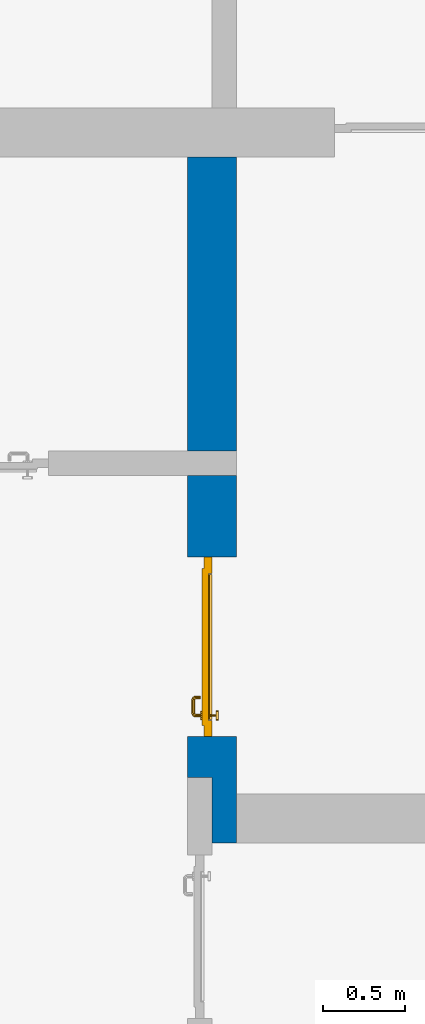
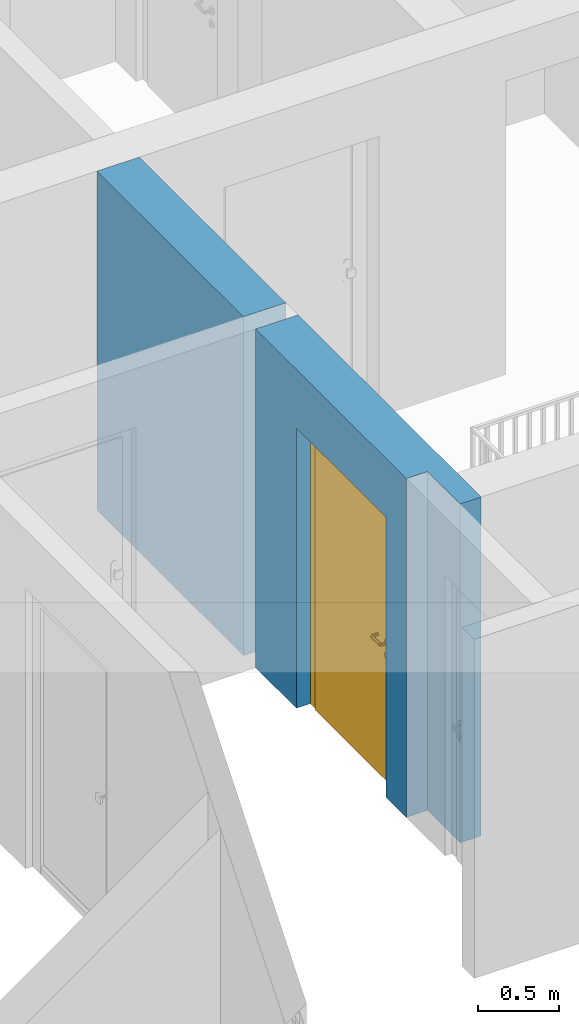
# One storey, part 13 of 54: 1 door, 1 wall, 1 opening.
"""IFC4 building model written with IfcOpenShell, lengths in metres."""

from ifc_helpers import new_model, entity, si_unit, converted_unit, derived_unit, direction, frame, origin_with_axes, place, context, subcontext, project, spatial, polygons, source, transform, mapped, material, type_object, element, fill, save


model = new_model("IFC4")

# Units and contexts
model_context = context("Model", 3, precision=1e-05, world=origin_with_axes(), true_north=direction((0.0, 1.0)))
body_context = subcontext(model_context, "Body", "Model", "MODEL_VIEW")
ifc_project = project(units=[si_unit("LENGTHUNIT", "METRE"), si_unit("AREAUNIT", "SQUARE_METRE"), si_unit("VOLUMEUNIT", "CUBIC_METRE"), converted_unit("PLANEANGLEUNIT", "DEGREE", entity("IfcPlaneAngleMeasure", 0.0174532925199), si_unit("PLANEANGLEUNIT", "RADIAN"), dimensions=[0, 0, 0, 0, 0, 0, 0]), converted_unit("TIMEUNIT", "Year", entity("IfcTimeMeasure", 31556926.0), si_unit("TIMEUNIT", "SECOND"), dimensions=[0, 0, 1, 0, 0, 0, 0]), si_unit("MASSUNIT", "GRAM", prefix="KILO"), si_unit("THERMODYNAMICTEMPERATUREUNIT", "DEGREE_CELSIUS"), si_unit("LUMINOUSINTENSITYUNIT", "LUMEN"), si_unit("ENERGYUNIT", "JOULE", prefix="MEGA"), derived_unit("THERMALCONDUCTANCEUNIT", [(si_unit("POWERUNIT", "WATT"), 1), (si_unit("LENGTHUNIT", "METRE"), -1), (si_unit("THERMODYNAMICTEMPERATUREUNIT", "KELVIN"), -1)]), derived_unit("SPECIFICHEATCAPACITYUNIT", [(si_unit("ENERGYUNIT", "JOULE"), 1), (si_unit("MASSUNIT", "GRAM", prefix="KILO"), -1), (si_unit("THERMODYNAMICTEMPERATUREUNIT", "KELVIN"), -1)]), derived_unit("MASSDENSITYUNIT", [(si_unit("MASSUNIT", "GRAM", prefix="KILO"), 1), (si_unit("VOLUMEUNIT", "CUBIC_METRE"), -1)])], contexts=[model_context])

# Site, building, storey
site_placement = place(None, origin_with_axes())
site = spatial("IfcSite", under=ifc_project, at=site_placement, CompositionType="ELEMENT")
building_placement = place(site_placement, origin_with_axes())
building = spatial("IfcBuilding", under=site, at=building_placement, CompositionType="ELEMENT")
storey_placement = place(building_placement, frame((0.0, 0.0, 9.18), z_axis=(0.0, 0.0, 1.0), x_axis=(1.0, 0.0, 0.0)))
storey = spatial("IfcBuildingStorey", under=building, at=storey_placement, Name="3. Geschoss", CompositionType="ELEMENT", Elevation=9.18)

# Wall, opening, door
ifc_material = material()
wall_type = type_object("IfcWallType", Name="300", PredefinedType="NOTDEFINED")
wall_placement = place(storey_placement, frame((-5.2421993804, -2.52881223104, 0.0), z_axis=(0.0, 0.0, 1.0), x_axis=(0.0, 1.0, 0.0)))
wall = element("IfcWall", 1, at=wall_placement, inside=storey, type_object=wall_type, material=ifc_material, Name="Wand-001", PredefinedType="NOTDEFINED", context=body_context, shape_type="Tessellation", body=[
    polygons([(0.35, -0.15, 2.1), (1.45, -0.15, 2.1), (1.45, -0.3, 2.1), (0.35, -0.3, 2.1), (0.35, 0.0, 2.1), (1.45, 0.0, 2.1), (1.45, -0.15, 0.0), (1.45, -0.3, 0.0), (1.95, -0.3, 2.54), (-0.3, -0.3, 2.54), (-0.3, -0.3, 0.0), (0.35, -0.3, 0.0), (1.95, -0.3, 0.0), (0.35, -0.15, 0.0), (0.35, 0.0, 0.0), (0.1, 0.0, 0.0), (0.1, 0.0, 2.54), (1.95, 0.0, 2.54), (1.95, 0.0, 0.0), (1.45, 0.0, 0.0), (-0.3, -0.15, 2.54), (0.1, -0.15, 2.54), (-0.3, -0.15, 0.0), (0.1, -0.15, 0.0)], [[[1, 2, 3, 4]], [[2, 1, 5, 6]], [[2, 7, 8, 3]], [[9, 10, 11, 12, 4, 3, 8, 13]], [[14, 1, 4, 12]], [[1, 14, 15, 5]], [[5, 15, 16, 17, 18, 19, 20, 6]], [[7, 2, 6, 20]], [[7, 20, 19, 13, 8]], [[21, 10, 9, 18, 17, 22]], [[21, 23, 11, 10]], [[15, 14, 12, 11, 23, 24, 16]], [[9, 13, 19, 18]], [[17, 16, 24, 22]], [[22, 24, 23, 21]]], closed=True),
    polygons([(3.9, 0.0, 0.0), (3.9, 0.0, 2.54), (3.9, -0.3, 2.54), (3.9, -0.3, 0.0), (2.1, 0.0, 0.0), (2.1, 0.0, 2.54), (2.1, -0.3, 2.54), (2.1, -0.3, 0.0)], [[[1, 2, 3, 4]], [[5, 6, 2, 1]], [[6, 7, 3, 2]], [[4, 3, 7, 8]], [[5, 1, 4, 8]], [[8, 7, 6, 5]]], closed=True),
])
opening_placement = place(wall_placement, frame((0.9, 0.0, 0.0), z_axis=(0.0, 0.0, 1.0), x_axis=(1.0, 0.0, 0.0)))
opening = element("IfcOpeningElement", 2, at=opening_placement, cuts=wall, context=body_context, identifier="Reference", shape_type="Tessellation", body=[
    polygons([(0.55, -0.15, 0.0), (0.55, -0.15, 2.1), (0.55, -0.301, 2.1), (0.55, -0.301, 0.0), (0.55, 0.001, 0.0), (0.55, 0.001, 2.1), (-0.55, -0.15, 2.1), (-0.55, -0.301, 2.1), (-0.55, 0.001, 2.1), (-0.55, -0.301, 0.0), (-0.55, -0.15, 0.0), (-0.55, 0.001, 0.0)], [[[1, 2, 3, 4]], [[2, 1, 5, 6]], [[7, 8, 3, 2, 6, 9]], [[8, 10, 4, 3]], [[1, 4, 10, 11, 12, 5]], [[6, 5, 12, 9]], [[7, 11, 10, 8]], [[11, 7, 9, 12]]], closed=True),
])
door_type = type_object("IfcDoorType", Name="Eingang 01 1-Fl 26", OperationType="SINGLE_SWING_RIGHT", PredefinedType="DOOR")
shared_shape = source(origin_with_axes(), body_context, "Body", "Tessellation", [
    polygons([(0.55, -0.05, 0.0), (0.55, -0.03, 0.0), (0.55, -0.03, 2.1), (0.55, -0.05, 2.1), (0.45, -0.05, 0.0), (0.45, -0.03, 0.0), (0.45, -0.03, 2.0), (0.1301, -0.03, 2.0), (0.0001, -0.03, 2.0), (-0.45, -0.03, 2.0), (-0.45, -0.03, 0.0), (-0.55, -0.03, 0.0), (-0.55, -0.03, 2.1), (-0.55, -0.05, 2.1), (-0.55, -0.05, 0.0), (-0.45, -0.05, 0.0), (-0.45, -0.05, 2.0), (0.0001, -0.05, 2.0), (0.1301, -0.05, 2.0), (0.45, -0.05, 2.0)], [[[1, 2, 3, 4]], [[5, 6, 2, 1]], [[2, 6, 7, 8, 9, 10, 11, 12, 13, 3]], [[4, 3, 13, 14]], [[1, 4, 14, 15, 16, 17, 18, 19, 20, 5]], [[20, 7, 6, 5]], [[19, 8, 7, 20]], [[18, 9, 8, 19]], [[17, 10, 9, 18]], [[16, 11, 10, 17]], [[15, 12, 11, 16]], [[14, 13, 12, 15]]], closed=True),
    polygons([(0.55, -0.03, 0.0), (0.55, 0.0, 0.0), (0.55, 0.0, 2.1), (0.55, -0.03, 2.1), (0.48, -0.03, 0.0), (0.48, 0.0, 0.0), (0.48, 0.0, 2.03), (0.1001, 0.0, 2.03), (0.0301, 0.0, 2.03), (-0.48, 0.0, 2.03), (-0.48, 0.0, 0.0), (-0.55, 0.0, 0.0), (-0.55, 0.0, 2.1), (-0.55, -0.03, 2.1), (-0.55, -0.03, 0.0), (-0.48, -0.03, 0.0), (-0.48, -0.03, 2.03), (0.0301, -0.03, 2.03), (0.1001, -0.03, 2.03), (0.48, -0.03, 2.03)], [[[1, 2, 3, 4]], [[5, 6, 2, 1]], [[2, 6, 7, 8, 9, 10, 11, 12, 13, 3]], [[4, 3, 13, 14]], [[1, 4, 14, 15, 16, 17, 18, 19, 20, 5]], [[20, 7, 6, 5]], [[19, 8, 7, 20]], [[18, 9, 8, 19]], [[17, 10, 9, 18]], [[16, 11, 10, 17]], [[15, 12, 11, 16]], [[14, 13, 12, 15]]], closed=True),
    polygons([(0.48, 0.01, 0.0), (-0.48, 0.01, 0.0), (-0.48, 0.01, 2.03), (0.48, 0.01, 2.03), (0.48, -0.03, 0.0), (-0.48, -0.03, 0.0), (-0.48, -0.03, 2.03), (0.48, -0.03, 2.03)], [[[1, 2, 3, 4]], [[2, 1, 5, 6]], [[3, 2, 6, 7]], [[4, 3, 7, 8]], [[1, 4, 8, 5]], [[6, 5, 8, 7]]], closed=True),
    polygons([(0.445, -0.05, 0.0), (0.445, -0.05, 0.05), (-0.445, -0.05, 0.05), (-0.445, -0.05, 0.0), (0.445, -0.03, 0.0), (0.445, -0.03, 0.07), (0.445, -0.035, 0.07), (-0.445, -0.035, 0.07), (-0.445, -0.03, 0.07), (-0.445, -0.03, 0.0)], [[[1, 2, 3, 4]], [[1, 5, 6, 7, 2]], [[2, 7, 8, 3]], [[4, 3, 8, 9, 10]], [[5, 1, 4, 10]], [[6, 5, 10, 9]], [[7, 6, 9, 8]]], closed=True),
    polygons([(-0.4335, 0.02, 1.0733826859), (-0.4335, 0.0199, 1.0733826859), (-0.42, 0.0199, 1.077), (-0.42, 0.02, 1.077), (-0.443382685902, 0.02, 1.0635), (-0.443382685902, 0.0199, 1.0635), (-0.4335, 0.0101, 1.0733826859), (-0.42, 0.0101, 1.077), (-0.4065, 0.0199, 1.0733826859), (-0.4065, 0.02, 1.0733826859), (-0.396617314098, 0.02, 1.0635), (-0.393, 0.02, 1.05), (-0.396617314098, 0.02, 1.0365), (-0.4065, 0.02, 1.0266173141), (-0.42, 0.02, 1.023), (-0.4335, 0.02, 1.0266173141), (-0.443382685902, 0.02, 1.0365), (-0.447, 0.02, 1.05), (-0.447, 0.0199, 1.05), (-0.443382685902, 0.0101, 1.0635), (-0.4335, 0.01, 1.0733826859), (-0.42, 0.01, 1.077), (-0.4065, 0.0101, 1.0733826859), (-0.396617314098, 0.0199, 1.0635), (-0.393, 0.0199, 1.05), (-0.396617314098, 0.0199, 1.0365), (-0.4065, 0.0199, 1.0266173141), (-0.42, 0.0199, 1.023), (-0.4335, 0.0199, 1.0266173141), (-0.443382685902, 0.0199, 1.0365), (-0.447, 0.0101, 1.05), (-0.443382685902, 0.01, 1.0635), (-0.447, 0.01, 1.05), (-0.443382685902, 0.01, 1.0365), (-0.4335, 0.01, 1.0266173141), (-0.42, 0.01, 1.023), (-0.4065, 0.01, 1.0266173141), (-0.396617314098, 0.01, 1.0365), (-0.393, 0.01, 1.05), (-0.396617314098, 0.01, 1.0635), (-0.4065, 0.01, 1.0733826859), (-0.396617314098, 0.0101, 1.0635), (-0.393, 0.0101, 1.05), (-0.396617314098, 0.0101, 1.0365), (-0.4065, 0.0101, 1.0266173141), (-0.42, 0.0101, 1.023), (-0.4335, 0.0101, 1.0266173141), (-0.443382685902, 0.0101, 1.0365)], [[[1, 2, 3, 4]], [[5, 6, 2, 1]], [[2, 7, 8, 3]], [[4, 3, 9, 10]], [[4, 10, 11, 12, 13, 14, 15, 16, 17, 18, 5, 1]], [[18, 19, 6, 5]], [[6, 20, 7, 2]], [[7, 21, 22, 8]], [[3, 8, 23, 9]], [[10, 9, 24, 11]], [[11, 24, 25, 12]], [[12, 25, 26, 13]], [[13, 26, 27, 14]], [[14, 27, 28, 15]], [[15, 28, 29, 16]], [[16, 29, 30, 17]], [[17, 30, 19, 18]], [[19, 31, 20, 6]], [[20, 32, 21, 7]], [[22, 21, 32, 33, 34, 35, 36, 37, 38, 39, 40, 41]], [[8, 22, 41, 23]], [[9, 23, 42, 24]], [[24, 42, 43, 25]], [[25, 43, 44, 26]], [[26, 44, 45, 27]], [[27, 45, 46, 28]], [[28, 46, 47, 29]], [[29, 47, 48, 30]], [[30, 48, 31, 19]], [[31, 33, 32, 20]], [[48, 34, 33, 31]], [[47, 35, 34, 48]], [[46, 36, 35, 47]], [[45, 37, 36, 46]], [[44, 38, 37, 45]], [[43, 39, 38, 44]], [[42, 40, 39, 43]], [[23, 41, 40, 42]]], closed=True),
    polygons([(-0.412532169224, 0.019, 0.959692280177), (-0.415, 0.019, 0.9544), (-0.415, 0.019, 0.952886751346), (-0.397569942042, 0.019, 0.96295), (-0.40705, 0.019, 0.972430057958), (-0.413279754556, 0.019, 0.961639806549), (-0.412532169224, 0.02, 0.959692280177), (-0.415, 0.02, 0.9544), (-0.415, 0.02, 0.952886751346), (-0.415, 0.02, 0.95), (-0.415, 0.02, 0.947113248654), (-0.415, 0.02, 0.941339745962), (-0.415, 0.02, 0.9375), (-0.415, 0.019, 0.9375), (-0.415, 0.019, 0.941339745962), (-0.415, 0.019, 0.947113248654), (-0.415, 0.019, 0.95), (-0.3941, 0.019, 0.95), (-0.397483339502, 0.019, 0.963), (-0.407, 0.019, 0.972516660498), (-0.414624817685, 0.019, 0.965143815798), (-0.42, 0.019, 0.9759), (-0.42, 0.019, 0.967425445323), (-0.414624817685, 0.02, 0.965143815798), (-0.413279754556, 0.02, 0.961639806549), (-0.40655, 0.02, 0.973296083362), (-0.396703916638, 0.02, 0.96345), (-0.3931, 0.02, 0.95), (-0.396703916638, 0.02, 0.93655), (-0.40655, 0.02, 0.926703916638), (-0.42, 0.02, 0.9231), (-0.42, 0.02, 0.9325), (-0.416464466094, 0.02, 0.933964466094), (-0.416464466094, 0.019, 0.933964466094), (-0.40705, 0.019, 0.927569942042), (-0.42, 0.019, 0.9325), (-0.42, 0.019, 0.9241), (-0.397569942042, 0.019, 0.93705), (-0.394, 0.019, 0.95), (-0.397483339502, 0.0189, 0.963), (-0.407, 0.0189, 0.972516660498), (-0.42, 0.019, 0.976), (-0.425375182315, 0.019, 0.965143815798), (-0.43295, 0.019, 0.972430057958), (-0.426720245444, 0.019, 0.961639806549), (-0.42, 0.02, 0.967425445323), (-0.42, 0.02, 0.9769), (-0.396617314098, 0.02, 0.9635), (-0.4065, 0.02, 0.973382685902), (-0.393, 0.02, 0.95), (-0.396617314098, 0.02, 0.9365), (-0.4065, 0.02, 0.926617314098), (-0.43345, 0.02, 0.926703916638), (-0.425, 0.02, 0.941339745962), (-0.425, 0.02, 0.9375), (-0.423535533906, 0.02, 0.933964466094), (-0.42, 0.02, 0.923), (-0.423535533906, 0.019, 0.933964466094), (-0.425, 0.019, 0.9375), (-0.425, 0.019, 0.941339745962), (-0.43295, 0.019, 0.927569942042), (-0.42, 0.019, 0.924), (-0.407, 0.019, 0.927483339502), (-0.397483339502, 0.019, 0.937), (-0.394, 0.0189, 0.95), (-0.397483339502, 0.0101, 0.963), (-0.407, 0.0101, 0.972516660498), (-0.42, 0.0189, 0.976), (-0.433, 0.019, 0.972516660498), (-0.425375182315, 0.02, 0.965143815798), (-0.427467830776, 0.019, 0.959692280177), (-0.442430057958, 0.019, 0.96295), (-0.425, 0.019, 0.952886751346), (-0.425, 0.019, 0.9544), (-0.427467830776, 0.02, 0.959692280177), (-0.426720245444, 0.02, 0.961639806549), (-0.43345, 0.02, 0.973296083362), (-0.42, 0.02, 0.977), (-0.396617314098, 0.0199, 0.9635), (-0.4065, 0.0199, 0.973382685902), (-0.393, 0.0199, 0.95), (-0.396617314098, 0.0199, 0.9365), (-0.4065, 0.0199, 0.926617314098), (-0.443296083362, 0.02, 0.93655), (-0.425, 0.02, 0.947113248654), (-0.425, 0.02, 0.9544), (-0.425, 0.019, 0.95), (-0.425, 0.019, 0.947113248654), (-0.425, 0.02, 0.95), (-0.425, 0.02, 0.952886751346), (-0.4335, 0.02, 0.926617314098), (-0.42, 0.0199, 0.923), (-0.442430057958, 0.019, 0.93705), (-0.433, 0.019, 0.927483339502), (-0.42, 0.0189, 0.924), (-0.407, 0.0189, 0.927483339502), (-0.397483339502, 0.0189, 0.937), (-0.394, 0.0101, 0.95), (-0.397483339502, 0.01, 0.963), (-0.407, 0.01, 0.972516660498), (-0.42, 0.0101, 0.976), (-0.433, 0.0189, 0.972516660498), (-0.442516660498, 0.019, 0.963), (-0.4459, 0.019, 0.95), (-0.443296083362, 0.02, 0.96345), (-0.4335, 0.02, 0.973382685902), (-0.42, 0.0199, 0.977), (-0.396617314098, 0.0101, 0.9635), (-0.4065, 0.0101, 0.973382685902), (-0.393, 0.0101, 0.95), (-0.396617314098, 0.0101, 0.9365), (-0.4065, 0.0101, 0.926617314098), (-0.443382685902, 0.02, 0.9365), (-0.4469, 0.02, 0.95), (-0.4335, 0.0199, 0.926617314098), (-0.42, 0.0101, 0.923), (-0.442516660498, 0.019, 0.937), (-0.433, 0.0189, 0.927483339502), (-0.42, 0.0101, 0.924), (-0.407, 0.0101, 0.927483339502), (-0.397483339502, 0.0101, 0.937), (-0.394, 0.01, 0.95), (-0.397396736961, 0.01, 0.96305), (-0.40695, 0.01, 0.972603263039), (-0.42, 0.01, 0.976), (-0.433, 0.0101, 0.972516660498), (-0.442516660498, 0.0189, 0.963), (-0.446, 0.019, 0.95), (-0.443382685902, 0.02, 0.9635), (-0.4335, 0.0199, 0.973382685902), (-0.42, 0.0101, 0.977), (-0.396617314098, 0.01, 0.9635), (-0.4065, 0.01, 0.973382685902), (-0.393, 0.01, 0.95), (-0.396617314098, 0.01, 0.9365), (-0.4065, 0.01, 0.926617314098), (-0.447, 0.02, 0.95), (-0.443382685902, 0.0199, 0.9365), (-0.4335, 0.0101, 0.926617314098), (-0.42, 0.01, 0.923), (-0.442516660498, 0.0189, 0.937), (-0.433, 0.0101, 0.927483339502), (-0.42, 0.01, 0.924), (-0.407, 0.01, 0.927483339502), (-0.397483339502, 0.01, 0.937), (-0.3939, 0.01, 0.95), (-0.396703916638, 0.01, 0.96345), (-0.40655, 0.01, 0.973296083362), (-0.42, 0.01, 0.9761), (-0.433, 0.01, 0.972516660498), (-0.442516660498, 0.0101, 0.963), (-0.446, 0.0189, 0.95), (-0.443382685902, 0.0199, 0.9635), (-0.4335, 0.0101, 0.973382685902), (-0.42, 0.01, 0.977), (-0.3931, 0.01, 0.95), (-0.396703916638, 0.01, 0.93655), (-0.40655, 0.01, 0.926703916638), (-0.447, 0.0199, 0.95), (-0.443382685902, 0.0101, 0.9365), (-0.4335, 0.01, 0.926617314098), (-0.42, 0.01, 0.9231), (-0.442516660498, 0.0101, 0.937), (-0.433, 0.01, 0.927483339502), (-0.42, 0.01, 0.9239), (-0.40695, 0.01, 0.927396736961), (-0.397396736961, 0.01, 0.93695), (-0.42, 0.01, 0.9769), (-0.43305, 0.01, 0.972603263039), (-0.442516660498, 0.01, 0.963), (-0.446, 0.0101, 0.95), (-0.443382685902, 0.0101, 0.9635), (-0.4335, 0.01, 0.973382685902), (-0.447, 0.0101, 0.95), (-0.443382685902, 0.01, 0.9365), (-0.43345, 0.01, 0.926703916638), (-0.442516660498, 0.01, 0.937), (-0.43305, 0.01, 0.927396736961), (-0.43345, 0.01, 0.973296083362), (-0.442603263039, 0.01, 0.96305), (-0.446, 0.01, 0.95), (-0.443382685902, 0.01, 0.9635), (-0.447, 0.01, 0.95), (-0.443296083362, 0.01, 0.93655), (-0.442603263039, 0.01, 0.93695), (-0.443296083362, 0.01, 0.96345), (-0.4461, 0.01, 0.95), (-0.4469, 0.01, 0.95)], [[[1, 2, 3, 4, 5, 6]], [[2, 1, 7, 8]], [[2, 8, 9, 10, 11, 12, 13, 14, 15, 16, 17, 3]], [[17, 18, 4, 3]], [[4, 19, 20, 5]], [[21, 6, 5, 22, 23]], [[1, 6, 21, 24, 25, 7]], [[7, 25, 26, 27, 9, 8]], [[9, 27, 28, 10]], [[10, 28, 29, 11]], [[11, 29, 30, 12]], [[31, 32, 33, 13, 12, 30]], [[14, 13, 33, 34]], [[35, 15, 14, 34, 36, 37]], [[15, 35, 38, 16]], [[16, 38, 18, 17]], [[18, 39, 19, 4]], [[19, 40, 41, 20]], [[5, 20, 42, 22]], [[43, 23, 22, 44, 45]], [[21, 23, 46, 24]], [[24, 46, 47, 26, 25]], [[48, 27, 26, 49]], [[50, 28, 27, 48]], [[51, 29, 28, 50]], [[52, 30, 29, 51]], [[53, 54, 55, 56, 32, 31]], [[34, 33, 32, 36]], [[57, 31, 30, 52]], [[37, 36, 58, 59, 60, 61]], [[37, 62, 63, 35]], [[35, 63, 64, 38]], [[38, 64, 39, 18]], [[39, 65, 40, 19]], [[40, 66, 67, 41]], [[20, 41, 68, 42]], [[22, 42, 69, 44]], [[23, 43, 70, 46]], [[71, 45, 44, 72, 73, 74]], [[43, 45, 71, 75, 76, 70]], [[70, 76, 77, 47, 46]], [[49, 26, 47, 78]], [[79, 48, 49, 80]], [[81, 50, 48, 79]], [[82, 51, 50, 81]], [[83, 52, 51, 82]], [[54, 53, 84, 85]], [[86, 74, 73, 87, 88, 60, 59, 55, 54, 85, 89, 90]], [[58, 56, 55, 59]], [[36, 32, 56, 58]], [[91, 53, 31, 57]], [[92, 57, 52, 83]], [[88, 93, 61, 60]], [[61, 94, 62, 37]], [[62, 95, 96, 63]], [[63, 96, 97, 64]], [[64, 97, 65, 39]], [[65, 98, 66, 40]], [[66, 99, 100, 67]], [[41, 67, 101, 68]], [[42, 68, 102, 69]], [[44, 69, 103, 72]], [[73, 72, 104, 87]], [[71, 74, 86, 75]], [[75, 86, 90, 105, 77, 76]], [[78, 47, 77, 106]], [[80, 49, 78, 107]], [[108, 79, 80, 109]], [[110, 81, 79, 108]], [[111, 82, 81, 110]], [[112, 83, 82, 111]], [[113, 84, 53, 91]], [[85, 84, 114, 89]], [[87, 104, 93, 88]], [[89, 114, 105, 90]], [[115, 91, 57, 92]], [[116, 92, 83, 112]], [[93, 117, 94, 61]], [[94, 118, 95, 62]], [[95, 119, 120, 96]], [[96, 120, 121, 97]], [[97, 121, 98, 65]], [[98, 122, 99, 66]], [[99, 123, 124, 100]], [[67, 100, 125, 101]], [[68, 101, 126, 102]], [[69, 102, 127, 103]], [[72, 103, 128, 104]], [[106, 77, 105, 129]], [[107, 78, 106, 130]], [[109, 80, 107, 131]], [[132, 108, 109, 133]], [[134, 110, 108, 132]], [[135, 111, 110, 134]], [[136, 112, 111, 135]], [[137, 114, 84, 113]], [[138, 113, 91, 115]], [[104, 128, 117, 93]], [[129, 105, 114, 137]], [[139, 115, 92, 116]], [[140, 116, 112, 136]], [[117, 141, 118, 94]], [[118, 142, 119, 95]], [[119, 143, 144, 120]], [[120, 144, 145, 121]], [[121, 145, 122, 98]], [[122, 146, 123, 99]], [[123, 147, 148, 124]], [[100, 124, 149, 125]], [[101, 125, 150, 126]], [[102, 126, 151, 127]], [[103, 127, 152, 128]], [[130, 106, 129, 153]], [[131, 107, 130, 154]], [[133, 109, 131, 155]], [[147, 132, 133, 148]], [[156, 134, 132, 147]], [[157, 135, 134, 156]], [[158, 136, 135, 157]], [[159, 137, 113, 138]], [[160, 138, 115, 139]], [[128, 152, 141, 117]], [[153, 129, 137, 159]], [[161, 139, 116, 140]], [[162, 140, 136, 158]], [[141, 163, 142, 118]], [[142, 164, 143, 119]], [[143, 165, 166, 144]], [[144, 166, 167, 145]], [[145, 167, 146, 122]], [[146, 156, 147, 123]], [[124, 148, 168, 149]], [[125, 149, 169, 150]], [[126, 150, 170, 151]], [[127, 151, 171, 152]], [[154, 130, 153, 172]], [[155, 131, 154, 173]], [[148, 133, 155, 168]], [[167, 157, 156, 146]], [[166, 158, 157, 167]], [[174, 159, 138, 160]], [[175, 160, 139, 161]], [[152, 171, 163, 141]], [[172, 153, 159, 174]], [[176, 161, 140, 162]], [[165, 162, 158, 166]], [[163, 177, 164, 142]], [[164, 178, 165, 143]], [[149, 168, 179, 169]], [[150, 169, 180, 170]], [[151, 170, 181, 171]], [[173, 154, 172, 182]], [[168, 155, 173, 179]], [[183, 174, 160, 175]], [[184, 175, 161, 176]], [[171, 181, 177, 163]], [[182, 172, 174, 183]], [[178, 176, 162, 165]], [[177, 185, 178, 164]], [[169, 179, 186, 180]], [[170, 180, 187, 181]], [[179, 173, 182, 186]], [[188, 183, 175, 184]], [[185, 184, 176, 178]], [[181, 187, 185, 177]], [[186, 182, 183, 188]], [[180, 186, 188, 187]], [[187, 188, 184, 185]]], closed=True),
    polygons([(-0.43, 0.02, 1.05), (-0.43, 0.0509849140336, 1.05), (-0.427071067812, 0.050696439392, 1.04292893219), (-0.427071067812, 0.02, 1.04292893219), (-0.427071067812, 0.02, 1.05707106781), (-0.427071067812, 0.050696439392, 1.05707106781), (-0.428277987014, 0.0596420579258, 1.05), (-0.425518993221, 0.0584992452783, 1.04292893219), (-0.42, 0.05, 1.04), (-0.42, 0.02, 1.04), (-0.42, 0.02, 1.06), (-0.42, 0.05, 1.06), (-0.425518993221, 0.0584992452783, 1.05707106781), (-0.422816199938, 0.0678161999379, 1.05), (-0.420704557509, 0.0657045575088, 1.04292893219), (-0.418858192988, 0.0557402514855, 1.04), (-0.412928932188, 0.049303560608, 1.04292893219), (-0.412928932188, 0.02, 1.04292893219), (-0.412928932188, 0.02, 1.05707106781), (-0.412928932188, 0.049303560608, 1.05707106781), (-0.418858192988, 0.0557402514855, 1.06), (-0.420704557509, 0.0657045575088, 1.05707106781), (-0.414642057926, 0.0732779870137, 1.05), (-0.413499245278, 0.0705189932208, 1.04292893219), (-0.415606601718, 0.0606066017178, 1.04), (-0.412197392755, 0.0529812576926, 1.04292893219), (-0.41, 0.0490150859664, 1.05), (-0.41, 0.02, 1.05), (-0.412197392755, 0.0529812576926, 1.05707106781), (-0.415606601718, 0.0606066017178, 1.06), (-0.413499245278, 0.0705189932208, 1.05707106781), (-0.405984914034, 0.075, 1.05), (-0.405696439392, 0.0720710678119, 1.04292893219), (-0.410740251485, 0.0638581929877, 1.04), (-0.410508645927, 0.0555086459268, 1.04292893219), (-0.409438398962, 0.0518384450452, 1.05), (-0.410508645927, 0.0555086459268, 1.05707106781), (-0.410740251485, 0.0638581929877, 1.06), (-0.405696439392, 0.0720710678119, 1.05707106781), (-0.324015085966, 0.075, 1.05), (-0.324303560608, 0.0720710678119, 1.04292893219), (-0.405, 0.065, 1.04), (-0.407981257693, 0.0571973927545, 1.04292893219), (-0.408397003498, 0.0533970034977, 1.05), (-0.407981257693, 0.0571973927545, 1.05707106781), (-0.405, 0.065, 1.06), (-0.324303560608, 0.0720710678119, 1.05707106781), (-0.315357942074, 0.0732779870137, 1.05), (-0.316500754722, 0.0705189932208, 1.04292893219), (-0.325, 0.065, 1.04), (-0.404303560608, 0.0579289321881, 1.04292893219), (-0.406838445045, 0.0544383989617, 1.05), (-0.404303560608, 0.0579289321881, 1.05707106781), (-0.325, 0.065, 1.06), (-0.316500754722, 0.0705189932208, 1.05707106781), (-0.307183800062, 0.0678161999379, 1.05), (-0.309295442491, 0.0657045575088, 1.04292893219), (-0.319259748515, 0.0638581929877, 1.04), (-0.325696439392, 0.0579289321881, 1.04292893219), (-0.404015085966, 0.055, 1.05), (-0.325696439392, 0.0579289321881, 1.05707106781), (-0.319259748515, 0.0638581929877, 1.06), (-0.309295442491, 0.0657045575088, 1.05707106781), (-0.301722012986, 0.0596420579258, 1.05), (-0.304481006779, 0.0584992452783, 1.04292893219), (-0.314393398282, 0.0606066017178, 1.04), (-0.322018742307, 0.0571973927545, 1.04292893219), (-0.325984914034, 0.055, 1.05), (-0.322018742307, 0.0571973927545, 1.05707106781), (-0.314393398282, 0.0606066017178, 1.06), (-0.304481006779, 0.0584992452783, 1.05707106781), (-0.3, 0.0509849140336, 1.05), (-0.302928932188, 0.050696439392, 1.04292893219), (-0.311141807012, 0.0557402514855, 1.04), (-0.319491354073, 0.0555086459268, 1.04292893219), (-0.323161554955, 0.0544383989617, 1.05), (-0.319491354073, 0.0555086459268, 1.05707106781), (-0.311141807012, 0.0557402514855, 1.06), (-0.302928932188, 0.050696439392, 1.05707106781), (-0.3, 0.02, 1.05), (-0.302928932188, 0.02, 1.04292893219), (-0.31, 0.05, 1.04), (-0.317802607245, 0.0529812576926, 1.04292893219), (-0.321602996502, 0.0533970034977, 1.05), (-0.317802607245, 0.0529812576926, 1.05707106781), (-0.31, 0.05, 1.06), (-0.302928932188, 0.02, 1.05707106781), (-0.31, 0.02, 1.06), (-0.317071067812, 0.02, 1.05707106781), (-0.32, 0.02, 1.05), (-0.317071067812, 0.02, 1.04292893219), (-0.31, 0.02, 1.04), (-0.317071067812, 0.049303560608, 1.04292893219), (-0.320561601038, 0.0518384450452, 1.05), (-0.317071067812, 0.049303560608, 1.05707106781), (-0.32, 0.0490150859664, 1.05)], [[[1, 2, 3, 4]], [[5, 6, 2, 1]], [[2, 7, 8, 3]], [[4, 3, 9, 10]], [[11, 12, 6, 5]], [[6, 13, 7, 2]], [[7, 14, 15, 8]], [[3, 8, 16, 9]], [[10, 9, 17, 18]], [[19, 20, 12, 11]], [[12, 21, 13, 6]], [[13, 22, 14, 7]], [[14, 23, 24, 15]], [[8, 15, 25, 16]], [[9, 16, 26, 17]], [[18, 17, 27, 28]], [[28, 27, 20, 19]], [[20, 29, 21, 12]], [[21, 30, 22, 13]], [[22, 31, 23, 14]], [[23, 32, 33, 24]], [[15, 24, 34, 25]], [[16, 25, 35, 26]], [[17, 26, 36, 27]], [[27, 36, 29, 20]], [[29, 37, 30, 21]], [[30, 38, 31, 22]], [[31, 39, 32, 23]], [[32, 40, 41, 33]], [[24, 33, 42, 34]], [[25, 34, 43, 35]], [[26, 35, 44, 36]], [[36, 44, 37, 29]], [[37, 45, 38, 30]], [[38, 46, 39, 31]], [[39, 47, 40, 32]], [[40, 48, 49, 41]], [[33, 41, 50, 42]], [[34, 42, 51, 43]], [[35, 43, 52, 44]], [[44, 52, 45, 37]], [[45, 53, 46, 38]], [[46, 54, 47, 39]], [[47, 55, 48, 40]], [[48, 56, 57, 49]], [[41, 49, 58, 50]], [[42, 50, 59, 51]], [[43, 51, 60, 52]], [[52, 60, 53, 45]], [[53, 61, 54, 46]], [[54, 62, 55, 47]], [[55, 63, 56, 48]], [[56, 64, 65, 57]], [[49, 57, 66, 58]], [[50, 58, 67, 59]], [[51, 59, 68, 60]], [[60, 68, 61, 53]], [[61, 69, 62, 54]], [[62, 70, 63, 55]], [[63, 71, 64, 56]], [[64, 72, 73, 65]], [[57, 65, 74, 66]], [[58, 66, 75, 67]], [[59, 67, 76, 68]], [[68, 76, 69, 61]], [[69, 77, 70, 62]], [[70, 78, 71, 63]], [[71, 79, 72, 64]], [[72, 80, 81, 73]], [[65, 73, 82, 74]], [[66, 74, 83, 75]], [[67, 75, 84, 76]], [[76, 84, 77, 69]], [[77, 85, 78, 70]], [[78, 86, 79, 71]], [[79, 87, 80, 72]], [[80, 87, 88, 89, 90, 91, 92, 81]], [[73, 81, 92, 82]], [[74, 82, 93, 83]], [[75, 83, 94, 84]], [[84, 94, 85, 77]], [[85, 95, 86, 78]], [[86, 88, 87, 79]], [[95, 89, 88, 86]], [[96, 90, 89, 95]], [[93, 91, 90, 96]], [[82, 92, 91, 93]], [[83, 93, 96, 94]], [[94, 96, 95, 85]]], closed=False),
    polygons([(-0.414696699141, -0.035, 1.04469669914), (-0.42, -0.035, 1.0425), (-0.425303300859, -0.035, 1.04469669914), (-0.4275, -0.035, 1.05), (-0.425303300859, -0.035, 1.05530330086), (-0.42, -0.035, 1.0575), (-0.414696699141, -0.035, 1.05530330086), (-0.4125, -0.035, 1.05), (-0.414696699141, -0.075, 1.04469669914), (-0.42, -0.075, 1.0425), (-0.425303300859, -0.075, 1.04469669914), (-0.4275, -0.075, 1.05), (-0.425303300859, -0.075, 1.05530330086), (-0.42, -0.075, 1.0575), (-0.414696699141, -0.075, 1.05530330086), (-0.4125, -0.075, 1.05)], [[[1, 2, 3, 4, 5, 6, 7, 8]], [[2, 1, 9, 10]], [[3, 2, 10, 11]], [[4, 3, 11, 12]], [[5, 4, 12, 13]], [[6, 5, 13, 14]], [[7, 6, 14, 15]], [[8, 7, 15, 16]], [[1, 8, 16, 9]], [[9, 16, 15, 14, 13, 12, 11, 10]]], closed=True),
    polygons([(-0.445, -0.03, 0.975), (-0.443096988313, -0.03, 0.965432914191), (-0.443096988313, -0.035, 0.965432914191), (-0.445, -0.035, 0.975), (-0.445, -0.03, 1.1), (-0.443096988313, -0.03, 1.10956708581), (-0.43767766953, -0.03, 1.11767766953), (-0.429567085809, -0.03, 1.12309698831), (-0.42, -0.03, 1.125), (-0.410432914191, -0.03, 1.12309698831), (-0.40232233047, -0.03, 1.11767766953), (-0.396903011687, -0.03, 1.10956708581), (-0.395, -0.03, 1.1), (-0.395, -0.03, 0.975), (-0.396903011687, -0.03, 0.965432914191), (-0.40232233047, -0.03, 0.95732233047), (-0.410432914191, -0.03, 0.951903011687), (-0.42, -0.03, 0.95), (-0.429567085809, -0.03, 0.951903011687), (-0.43767766953, -0.03, 0.95732233047), (-0.43767766953, -0.035, 0.95732233047), (-0.429567085809, -0.035, 0.951903011687), (-0.42, -0.035, 0.95), (-0.410432914191, -0.035, 0.951903011687), (-0.40232233047, -0.035, 0.95732233047), (-0.396903011687, -0.035, 0.965432914191), (-0.395, -0.035, 0.975), (-0.395, -0.035, 1.1), (-0.396903011687, -0.035, 1.10956708581), (-0.40232233047, -0.035, 1.11767766953), (-0.410432914191, -0.035, 1.12309698831), (-0.42, -0.035, 1.125), (-0.429567085809, -0.035, 1.12309698831), (-0.43767766953, -0.035, 1.11767766953), (-0.443096988313, -0.035, 1.10956708581), (-0.445, -0.035, 1.1)], [[[1, 2, 3, 4]], [[1, 5, 6, 7, 8, 9, 10, 11, 12, 13, 14, 15, 16, 17, 18, 19, 20, 2]], [[2, 20, 21, 3]], [[4, 3, 21, 22, 23, 24, 25, 26, 27, 28, 29, 30, 31, 32, 33, 34, 35, 36]], [[5, 1, 4, 36]], [[6, 5, 36, 35]], [[7, 6, 35, 34]], [[8, 7, 34, 33]], [[9, 8, 33, 32]], [[10, 9, 32, 31]], [[11, 10, 31, 30]], [[12, 11, 30, 29]], [[13, 12, 29, 28]], [[14, 13, 28, 27]], [[15, 14, 27, 26]], [[16, 15, 26, 25]], [[17, 16, 25, 24]], [[18, 17, 24, 23]], [[19, 18, 23, 22]], [[20, 19, 22, 21]]], closed=True),
    polygons([(-0.44, -0.075, 1.08), (-0.445, -0.075, 1.07866025404), (-0.445, -0.09, 1.07866025404), (-0.44, -0.09, 1.08), (-0.4, -0.075, 1.08), (-0.395, -0.075, 1.07866025404), (-0.391339745962, -0.075, 1.075), (-0.39, -0.075, 1.07), (-0.39, -0.075, 1.03), (-0.391339745962, -0.075, 1.025), (-0.395, -0.075, 1.02133974596), (-0.4, -0.075, 1.02), (-0.44, -0.075, 1.02), (-0.445, -0.075, 1.02133974596), (-0.448660254038, -0.075, 1.025), (-0.45, -0.075, 1.03), (-0.45, -0.075, 1.07), (-0.448660254038, -0.075, 1.075), (-0.448660254038, -0.09, 1.075), (-0.45, -0.09, 1.07), (-0.45, -0.09, 1.03), (-0.448660254038, -0.09, 1.025), (-0.445, -0.09, 1.02133974596), (-0.44, -0.09, 1.02), (-0.4, -0.09, 1.02), (-0.395, -0.09, 1.02133974596), (-0.391339745962, -0.09, 1.025), (-0.39, -0.09, 1.03), (-0.39, -0.09, 1.07), (-0.391339745962, -0.09, 1.075), (-0.395, -0.09, 1.07866025404), (-0.4, -0.09, 1.08)], [[[1, 2, 3, 4]], [[1, 5, 6, 7, 8, 9, 10, 11, 12, 13, 14, 15, 16, 17, 18, 2]], [[2, 18, 19, 3]], [[4, 3, 19, 20, 21, 22, 23, 24, 25, 26, 27, 28, 29, 30, 31, 32]], [[5, 1, 4, 32]], [[6, 5, 32, 31]], [[7, 6, 31, 30]], [[8, 7, 30, 29]], [[9, 8, 29, 28]], [[10, 9, 28, 27]], [[11, 10, 27, 26]], [[12, 11, 26, 25]], [[13, 12, 25, 24]], [[14, 13, 24, 23]], [[15, 14, 23, 22]], [[16, 15, 22, 21]], [[17, 16, 21, 20]], [[18, 17, 20, 19]]], closed=True),
])
door_placement = place(opening_placement, frame((-0.45, 0.0, 0.0), z_axis=(0.0, 0.0, 1.0), x_axis=(1.0, 0.0, 0.0)))
door = element("IfcDoor", 3, at=door_placement, inside=storey, type_object=door_type, OverallHeight=2.1, OverallWidth=1.1, PredefinedType="DOOR", context=body_context, shape_type="MappedRepresentation", body=[
    mapped(shared_shape, transform((0.45, -0.1, 0.0))),
])
fill(opening, door)

save(model, "model.ifc")
